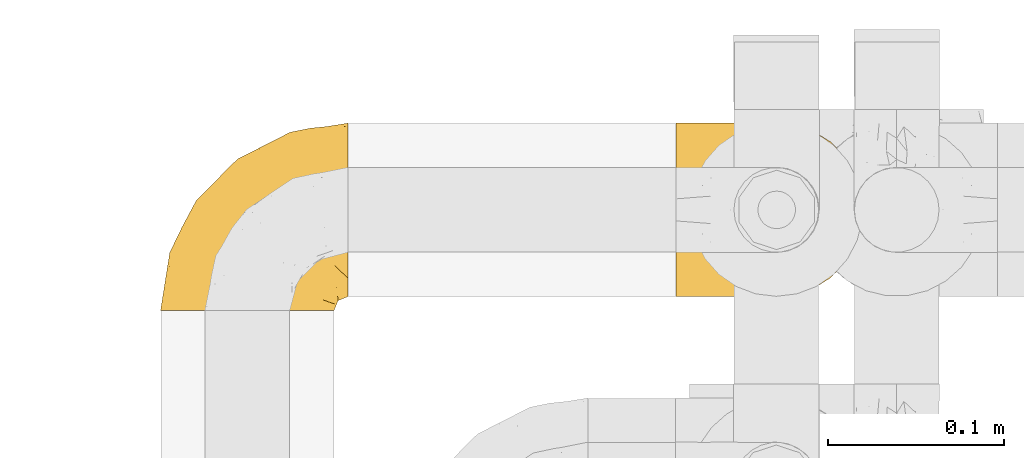
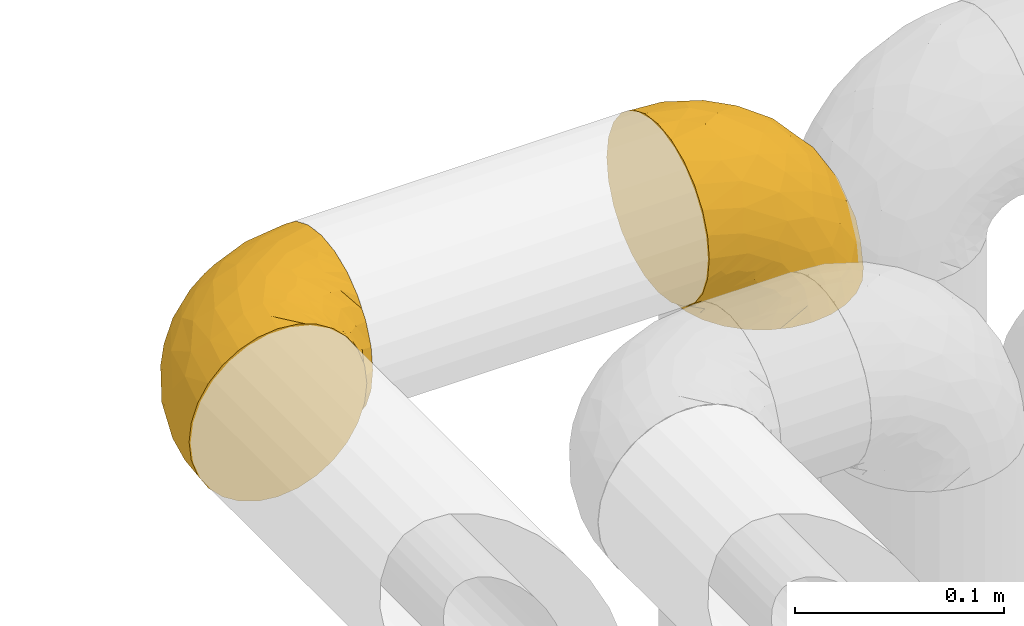
# One storey, part 401 of 827: 2 coverings.
"""IFC2X3 building model written with IfcOpenShell, lengths in millimetres."""

from ifc_helpers import new_model, entity, si_unit, converted_unit, derived_unit, direction, frame, origin, place, context, subcontext, project, spatial, faceted_brep, element, save


model = new_model("IFC2X3")

# Units and contexts
model_context = context("Model", 3, precision=0.01, world=origin(), true_north=direction((6.12303176911189e-17, 1.0)))
body_context = subcontext(model_context, "Body", "Model", "MODEL_VIEW")
ifc_project = project(units=[si_unit("LENGTHUNIT", "METRE", prefix="MILLI"), si_unit("AREAUNIT", "SQUARE_METRE"), si_unit("VOLUMEUNIT", "CUBIC_METRE"), converted_unit("PLANEANGLEUNIT", "DEGREE", entity("IfcRatioMeasure", 0.0174532925199433), si_unit("PLANEANGLEUNIT", "RADIAN"), dimensions=[0, 0, 0, 0, 0, 0, 0]), si_unit("MASSUNIT", "GRAM", prefix="KILO"), derived_unit("MASSDENSITYUNIT", [(si_unit("MASSUNIT", "GRAM", prefix="KILO"), 1), (si_unit("LENGTHUNIT", "METRE"), -3)]), derived_unit("MOMENTOFINERTIAUNIT", [(si_unit("LENGTHUNIT", "METRE"), 4)]), si_unit("TIMEUNIT", "SECOND"), si_unit("FREQUENCYUNIT", "HERTZ"), si_unit("THERMODYNAMICTEMPERATUREUNIT", "DEGREE_CELSIUS"), derived_unit("THERMALTRANSMITTANCEUNIT", [(si_unit("MASSUNIT", "GRAM", prefix="KILO"), 1), (si_unit("THERMODYNAMICTEMPERATUREUNIT", "KELVIN"), -1), (si_unit("TIMEUNIT", "SECOND"), -3)]), derived_unit("VOLUMETRICFLOWRATEUNIT", [(si_unit("LENGTHUNIT", "METRE"), 3), (si_unit("TIMEUNIT", "SECOND"), -1)]), derived_unit("MASSFLOWRATEUNIT", [(si_unit("MASSUNIT", "GRAM", prefix="KILO"), 1), (si_unit("TIMEUNIT", "SECOND"), -1)]), derived_unit("ROTATIONALFREQUENCYUNIT", [(si_unit("TIMEUNIT", "SECOND"), -1)]), si_unit("ELECTRICCURRENTUNIT", "AMPERE"), si_unit("ELECTRICVOLTAGEUNIT", "VOLT"), si_unit("POWERUNIT", "WATT"), si_unit("FORCEUNIT", "NEWTON", prefix="KILO"), si_unit("ILLUMINANCEUNIT", "LUX"), si_unit("LUMINOUSFLUXUNIT", "LUMEN"), si_unit("LUMINOUSINTENSITYUNIT", "CANDELA"), derived_unit("USERDEFINED", [(si_unit("MASSUNIT", "GRAM", prefix="KILO"), -1), (si_unit("LENGTHUNIT", "METRE"), -2), (si_unit("TIMEUNIT", "SECOND"), 3), (si_unit("LUMINOUSFLUXUNIT", "LUMEN"), 1)]), derived_unit("LINEARVELOCITYUNIT", [(si_unit("LENGTHUNIT", "METRE"), 1), (si_unit("TIMEUNIT", "SECOND"), -1)]), si_unit("PRESSUREUNIT", "PASCAL"), derived_unit("USERDEFINED", [(si_unit("LENGTHUNIT", "METRE"), -2), (si_unit("MASSUNIT", "GRAM", prefix="KILO"), 1), (si_unit("TIMEUNIT", "SECOND"), -2)]), derived_unit("LINEARFORCEUNIT", [(si_unit("MASSUNIT", "GRAM", prefix="KILO"), 1), (si_unit("LENGTHUNIT", "METRE"), 1), (si_unit("TIMEUNIT", "SECOND"), -2), (si_unit("LENGTHUNIT", "METRE"), -1)]), derived_unit("PLANARFORCEUNIT", [(si_unit("MASSUNIT", "GRAM", prefix="KILO"), 1), (si_unit("LENGTHUNIT", "METRE"), 1), (si_unit("TIMEUNIT", "SECOND"), -2), (si_unit("LENGTHUNIT", "METRE"), -2)])], contexts=[model_context])

# Site, building, storey
site_placement = place(None, origin())
site = spatial("IfcSite", under=ifc_project, at=site_placement, CompositionType="ELEMENT")
building_placement = place(site_placement, origin())
building = spatial("IfcBuilding", under=site, at=building_placement, CompositionType="ELEMENT")
storey_placement = place(building_placement, frame((0.0, 0.0, 28200.0)))
storey = spatial("IfcBuildingStorey", under=building, at=storey_placement, Name="08", CompositionType="ELEMENT", Elevation=28200.0)

# Coverings
covering_1_placement = place(storey_placement, frame((47301.25, 15248.43, 2949.25)))
element("IfcCovering", 1, at=covering_1_placement, inside=storey, Name=":ADSK_", ObjectType=":ADSK_", PredefinedType="INSULATION", context=body_context, shape_type="Brep", body=[
    faceted_brep([(50.75, 1.6, 99.9), (39.8, 1.6, 98.66), (29.41, 1.6, 95.02), (20.09, 1.6, 89.17), (12.31, 1.6, 81.38), (6.46, 1.6, 72.06), (2.83, 1.6, 61.68), (1.6, 1.6, 50.75), (2.83, 1.6, 39.8), (6.47, 1.6, 29.41), (12.32, 1.6, 20.09), (20.11, 1.6, 12.31), (29.43, 1.6, 6.46), (39.81, 1.6, 2.83), (50.75, 1.6, 1.6), (56.45, 1.6, 2.24), (61.69, 1.6, 2.83), (66.88, 1.6, 4.65), (72.08, 1.6, 6.47), (81.4, 1.6, 12.32), (89.18, 1.6, 20.11), (95.03, 1.6, 29.43), (98.66, 1.6, 39.81), (99.9, 1.6, 50.75), (98.66, 1.6, 61.69), (95.02, 1.6, 72.08), (89.17, 1.6, 81.4), (81.38, 1.6, 89.18), (72.06, 1.6, 95.03), (66.87, 1.6, 96.85), (61.68, 1.6, 98.66), (56.45, 1.6, 99.25), (53.6, 1.6, 99.57), (107.75, 11.12, 38.02), (107.75, 16.03, 26.17), (107.75, 19.94, 21.08), (107.75, 23.84, 15.99), (107.75, 28.93, 12.09), (107.75, 34.02, 8.18), (107.75, 39.95, 5.73), (107.75, 45.87, 3.27), (107.75, 52.86, 2.35), (107.75, 55.73, 1.97), (107.75, 58.6, 1.6), (107.75, 71.32, 3.27), (107.75, 83.17, 8.18), (107.75, 93.35, 15.99), (107.75, 101.16, 26.17), (107.75, 106.07, 38.02), (107.75, 107.75, 50.75), (107.75, 106.07, 63.47), (107.75, 101.16, 75.32), (107.75, 93.35, 85.5), (107.75, 83.17, 93.31), (107.75, 71.32, 98.22), (107.75, 58.6, 99.9), (107.75, 52.86, 99.14), (107.75, 45.87, 98.22), (107.75, 39.95, 95.77), (107.75, 34.02, 93.31), (107.75, 28.93, 89.4), (107.75, 23.84, 85.5), (107.75, 19.94, 80.41), (107.75, 16.03, 75.32), (107.75, 11.12, 63.47), (107.75, 9.45, 50.75), (39.38, 81.82, 59.31), (49.75, 84.02, 73.08), (57.38, 93.05, 63.72), (74.94, 102.55, 50.75), (85.97, 104.83, 58.64), (95.66, 105.83, 50.75), (67.82, 91.87, 76.74), (83.09, 101.74, 67.68), (89.16, 97.07, 78.92), (37.01, 38.45, 94.31), (43.46, 22.17, 98.76), (51.79, 42.04, 98.4), (85.58, 77.69, 94.57), (62.84, 75.76, 89.91), (62.77, 62.11, 96.32), (88.17, 66.08, 98.79), (85.93, 54.26, 99.9), (91.42, 55.35, 99.9), (96.91, 56.44, 99.9), (99.62, 56.98, 99.9), (102.33, 57.52, 99.9), (82.57, 87.84, 87.31), (32.75, 19.41, 95.61), (13.79, 48.89, 60.43), (6.77, 26.34, 65.24), (16.46, 44.55, 72.87), (55.08, 23.41, 99.9), (58.17, 28.03, 99.9), (61.26, 32.65, 99.9), (64.35, 37.28, 99.9), (67.44, 41.9, 99.9), (24.18, 20.6, 90.65), (23.37, 63.36, 63.14), (49.76, 62.21, 91.89), (9.84, 19.94, 75.25), (3.51, 13.68, 50.75), (55.75, 80.85, 82.18), (42.34, 66.53, 85.08), (37.78, 71.06, 76.93), (21.87, 63.99, 50.75), (33.61, 75.73, 50.75), (17.1, 26.77, 83.02), (51.28, 4.31, 99.9), (51.82, 7.01, 99.9), (52.9, 12.43, 99.9), (53.99, 17.92, 99.9), (28.01, 43.43, 87.13), (28.99, 56.23, 80.85), (69.9, 54.97, 99.17), (6.79, 34.4, 50.75), (72.06, 44.99, 99.9), (76.69, 48.08, 99.9), (81.31, 51.17, 99.9), (45.35, 87.47, 50.75), (34.79, 74.55, 67.61), (25.72, 60.86, 72.25), (14.33, 49.19, 50.75), (60.15, 95.01, 50.75), (62.38, 10.27, 98.69), (100.57, 48.79, 99.01), (91.06, 45.16, 98.79), (97.66, 44.99, 98.29), (97.55, 6.17, 68.51), (93.65, 7.65, 76.82), (66.85, 21.59, 98.54), (61.93, 19.96, 99.3), (101.4, 21.0, 83.57), (100.07, 27.2, 89.47), (101.36, 14.83, 75.76), (95.94, 19.7, 84.86), (96.3, 10.93, 75.89), (101.98, 9.63, 64.77), (85.88, 19.97, 90.83), (78.88, 21.13, 94.62), (82.8, 14.14, 90.37), (102.58, 30.2, 91.18), (82.88, 8.12, 88.65), (88.57, 9.93, 84.11), (88.67, 24.62, 91.75), (69.08, 11.87, 96.86), (102.19, 7.15, 50.75), (100.06, 5.32, 58.97), (70.56, 26.68, 98.37), (91.07, 13.92, 83.91), (77.56, 30.67, 97.52), (96.59, 36.65, 95.55), (86.38, 42.89, 98.76), (91.79, 34.04, 95.26), (81.71, 36.6, 98.04), (94.11, 26.41, 90.65), (76.09, 10.07, 93.51), (76.91, 15.83, 94.16), (81.44, 41.99, 99.1), (101.37, 14.83, 25.73), (94.12, 26.4, 10.84), (101.41, 21.01, 17.92), (95.96, 19.71, 16.64), (96.22, 5.72, 30.44), (66.85, 21.6, 2.95), (61.94, 19.96, 2.19), (58.17, 28.03, 1.6), (69.1, 11.87, 4.63), (88.58, 9.93, 17.39), (96.91, 56.44, 1.6), (102.33, 57.52, 1.6), (105.04, 58.06, 1.6), (82.9, 8.13, 12.86), (82.82, 14.15, 11.13), (97.66, 44.99, 3.2), (96.59, 36.65, 5.94), (100.07, 27.21, 12.02), (91.79, 34.04, 6.23), (102.58, 30.2, 10.31), (76.13, 10.06, 8.0), (76.93, 15.83, 7.34), (100.57, 48.79, 2.48), (86.38, 42.89, 2.73), (90.86, 45.38, 2.64), (52.9, 12.43, 1.6), (62.39, 10.28, 2.8), (101.98, 9.64, 36.71), (91.42, 55.35, 1.6), (85.93, 54.26, 1.6), (99.49, 6.05, 38.59), (51.82, 7.01, 1.6), (52.36, 9.72, 1.6), (61.26, 32.65, 1.6), (70.56, 26.68, 3.12), (91.09, 13.92, 17.59), (64.35, 37.28, 1.6), (77.6, 30.66, 3.98), (78.89, 21.14, 6.87), (81.71, 36.59, 3.45), (88.69, 24.6, 9.76), (53.99, 17.92, 1.6), (55.08, 23.41, 1.6), (96.31, 10.93, 25.62), (85.9, 19.97, 10.67), (81.45, 41.99, 2.39), (76.69, 48.08, 1.6), (81.31, 51.17, 1.6), (72.06, 44.99, 1.6), (67.44, 41.9, 1.6), (69.6, 55.26, 2.4), (85.97, 104.83, 42.85), (82.57, 87.84, 14.18), (63.16, 75.91, 11.56), (55.81, 80.84, 19.27), (67.81, 91.87, 24.75), (49.73, 83.98, 28.37), (32.55, 19.16, 5.95), (43.23, 22.37, 2.79), (88.17, 66.08, 2.71), (57.38, 93.05, 37.78), (83.08, 101.74, 33.81), (89.16, 97.07, 22.57), (85.58, 77.69, 6.92), (16.46, 44.55, 28.61), (6.77, 26.34, 36.24), (13.8, 48.9, 41.05), (37.71, 70.99, 24.55), (34.8, 74.55, 33.88), (36.83, 37.8, 7.11), (39.38, 81.82, 42.18), (17.12, 26.77, 18.46), (24.19, 20.6, 10.84), (28.89, 56.15, 20.69), (25.69, 60.85, 29.27), (51.77, 42.06, 3.1), (45.66, 57.03, 9.18), (23.39, 63.4, 38.38), (9.85, 19.94, 26.23), (28.11, 43.59, 14.34), (62.27, 62.61, 5.46), (42.35, 66.52, 16.39)], [[[0, 1, 2, 3, 4, 5, 6, 7, 8, 9, 10, 11, 12, 13, 14, 15, 16, 17, 18, 19, 20, 21, 22, 23, 24, 25, 26, 27, 28, 29, 30, 31, 32]], [[33, 34, 35, 36, 37, 38, 39, 40, 41, 42, 43, 44, 45, 46, 47, 48, 49, 50, 51, 52, 53, 54, 55, 56, 57, 58, 59, 60, 61, 62, 63, 64, 65]], [[66, 67, 68]], [[69, 70, 71]], [[68, 72, 73]], [[73, 72, 74]], [[75, 76, 77]], [[78, 79, 80]], [[51, 50, 73]], [[81, 82, 83, 84, 85, 86, 55]], [[52, 87, 53]], [[74, 52, 51]], [[2, 1, 88]], [[89, 90, 91]], [[77, 92, 93, 94, 95, 96]], [[55, 54, 81]], [[78, 53, 87]], [[5, 90, 6]], [[88, 76, 75]], [[97, 3, 2]], [[89, 91, 98]], [[99, 80, 79]], [[90, 5, 100]], [[74, 87, 52]], [[100, 5, 4]], [[90, 101, 6]], [[79, 102, 103]], [[102, 67, 104]], [[105, 98, 106]], [[107, 4, 3]], [[76, 0, 108, 109, 110, 111, 92]], [[107, 112, 113]], [[114, 77, 96]], [[89, 115, 90]], [[114, 96, 116, 117, 118, 82]], [[75, 97, 88]], [[119, 66, 68]], [[50, 71, 70]], [[100, 91, 90]], [[99, 77, 80]], [[102, 104, 103]], [[97, 107, 3]], [[80, 81, 78]], [[107, 97, 112]], [[68, 73, 70]], [[66, 98, 120]], [[78, 81, 54]], [[114, 81, 80]], [[53, 78, 54]], [[78, 87, 79]], [[102, 87, 72]], [[79, 103, 99]], [[4, 107, 100]], [[91, 100, 107]], [[88, 97, 2]], [[112, 97, 75]], [[99, 112, 75]], [[103, 104, 113]], [[91, 121, 98]], [[89, 105, 122, 115]], [[101, 90, 115]], [[101, 7, 6]], [[88, 1, 76]], [[0, 76, 1]], [[92, 77, 76]], [[73, 74, 51]], [[87, 74, 72]], [[81, 114, 82]], [[77, 114, 80]], [[87, 102, 79]], [[67, 102, 72]], [[68, 67, 72]], [[67, 120, 104]], [[120, 121, 104]], [[104, 121, 113]], [[121, 120, 98]], [[91, 107, 113]], [[91, 113, 121]], [[103, 113, 112]], [[106, 98, 66]], [[105, 89, 98]], [[106, 66, 119]], [[67, 66, 120]], [[68, 69, 123, 119]], [[50, 49, 71]], [[50, 70, 73]], [[112, 99, 103]], [[77, 99, 75]], [[69, 68, 70]], [[29, 124, 110]], [[84, 83, 125]], [[126, 82, 118]], [[59, 58, 127]], [[25, 128, 129]], [[130, 93, 131]], [[132, 62, 133]], [[134, 135, 136]], [[137, 65, 64]], [[64, 134, 137]], [[138, 139, 140]], [[111, 110, 124, 92]], [[134, 136, 137]], [[134, 64, 63]], [[141, 61, 60]], [[125, 58, 57]], [[142, 143, 140]], [[142, 26, 143]], [[127, 83, 82]], [[28, 124, 29]], [[108, 0, 32, 31, 30, 110, 109]], [[30, 29, 110]], [[135, 144, 138]], [[28, 145, 124]], [[57, 56, 55, 86, 85, 84]], [[146, 147, 23]], [[24, 23, 147]], [[25, 143, 26]], [[95, 94, 148]], [[24, 128, 25]], [[149, 138, 143]], [[124, 145, 131]], [[127, 58, 125]], [[150, 148, 139]], [[127, 126, 151]], [[151, 59, 127]], [[152, 151, 126]], [[153, 154, 155]], [[153, 133, 141]], [[145, 28, 27]], [[142, 156, 27]], [[157, 148, 130]], [[61, 133, 62]], [[134, 132, 135]], [[147, 128, 24]], [[65, 137, 146]], [[146, 137, 147]], [[128, 137, 136]], [[137, 128, 147]], [[128, 136, 129]], [[149, 129, 136]], [[25, 129, 143]], [[158, 152, 117]], [[152, 118, 117]], [[153, 151, 152]], [[158, 116, 154]], [[144, 150, 138]], [[153, 152, 158]], [[133, 153, 155]], [[133, 155, 132]], [[60, 151, 141]], [[135, 132, 155]], [[134, 63, 132]], [[144, 135, 155]], [[135, 138, 149]], [[155, 154, 144]], [[150, 154, 96]], [[154, 150, 144]], [[148, 94, 130]], [[82, 126, 127]], [[118, 152, 126]], [[150, 96, 95]], [[139, 148, 157]], [[150, 95, 148]], [[93, 92, 131]], [[130, 145, 156]], [[130, 94, 93]], [[84, 125, 57]], [[127, 125, 83]], [[140, 139, 157]], [[150, 139, 138]], [[140, 157, 142]], [[138, 140, 143]], [[156, 142, 157]], [[27, 26, 142]], [[130, 156, 157]], [[145, 27, 156]], [[132, 63, 62]], [[124, 131, 92]], [[130, 131, 145]], [[129, 149, 143]], [[135, 149, 136]], [[141, 133, 61]], [[60, 59, 151]], [[141, 151, 153]], [[116, 96, 154]], [[153, 158, 154]], [[158, 117, 116]], [[34, 33, 159]], [[160, 161, 162]], [[22, 21, 163]], [[164, 165, 166]], [[19, 18, 167]], [[168, 21, 20]], [[42, 41, 40, 169, 170, 171, 43]], [[172, 173, 168]], [[174, 38, 175]], [[176, 177, 178]], [[179, 164, 180]], [[40, 181, 169]], [[182, 183, 175]], [[17, 184, 185]], [[65, 146, 186]], [[187, 174, 188]], [[23, 22, 189]], [[174, 39, 38]], [[15, 14, 190, 191, 184, 16]], [[181, 40, 39]], [[192, 193, 164]], [[194, 163, 168]], [[33, 186, 159]], [[180, 173, 172]], [[195, 196, 193]], [[18, 185, 167]], [[173, 180, 197]], [[198, 199, 196]], [[200, 201, 185, 184]], [[184, 17, 16]], [[18, 17, 185]], [[202, 159, 186]], [[194, 168, 203]], [[189, 163, 202]], [[204, 205, 182]], [[187, 181, 174]], [[160, 177, 176]], [[206, 183, 182]], [[206, 182, 205]], [[201, 165, 185]], [[165, 164, 167]], [[172, 179, 180]], [[202, 194, 162]], [[176, 161, 160]], [[65, 186, 33]], [[163, 189, 22]], [[175, 177, 182]], [[174, 183, 188]], [[177, 198, 204]], [[199, 160, 162]], [[198, 207, 204]], [[175, 38, 37]], [[198, 177, 160]], [[178, 177, 175]], [[176, 35, 161]], [[34, 159, 161]], [[162, 161, 159]], [[202, 162, 159]], [[199, 162, 203]], [[196, 199, 203]], [[198, 160, 199]], [[193, 197, 180]], [[208, 198, 196]], [[188, 183, 206]], [[175, 183, 174]], [[193, 192, 195]], [[195, 208, 196]], [[197, 196, 203]], [[180, 164, 193]], [[168, 163, 21]], [[166, 165, 201]], [[166, 192, 164]], [[189, 202, 186]], [[186, 146, 189]], [[23, 189, 146]], [[174, 181, 39]], [[169, 181, 187]], [[196, 197, 193]], [[173, 203, 168]], [[203, 173, 197]], [[172, 168, 20]], [[20, 19, 172]], [[179, 172, 19]], [[19, 167, 179]], [[164, 179, 167]], [[35, 176, 36]], [[35, 34, 161]], [[185, 165, 167]], [[162, 194, 203]], [[163, 194, 202]], [[176, 178, 36]], [[37, 36, 178]], [[175, 37, 178]], [[177, 204, 182]], [[207, 198, 208]], [[207, 205, 204]], [[209, 188, 206, 205, 207, 208]], [[48, 210, 71]], [[211, 212, 213]], [[214, 213, 215]], [[216, 217, 13]], [[218, 43, 171, 170, 169, 187, 188]], [[219, 220, 214]], [[47, 46, 221]], [[210, 48, 220]], [[211, 222, 212]], [[222, 45, 44]], [[221, 220, 47]], [[47, 220, 48]], [[221, 211, 214]], [[223, 224, 225]], [[211, 46, 45]], [[226, 227, 215]], [[43, 218, 44]], [[217, 216, 228]], [[219, 215, 229]], [[14, 13, 217]], [[224, 9, 8]], [[10, 230, 11]], [[11, 231, 12]], [[232, 223, 233]], [[234, 208, 195, 192, 166, 201]], [[235, 234, 228]], [[222, 44, 218]], [[106, 229, 236]], [[224, 237, 9]], [[231, 238, 228]], [[9, 237, 10]], [[115, 224, 101]], [[239, 234, 235]], [[231, 11, 230]], [[223, 230, 237]], [[224, 8, 101]], [[223, 236, 233]], [[225, 115, 122, 105]], [[216, 12, 231]], [[209, 234, 239]], [[210, 219, 69]], [[219, 214, 215]], [[229, 119, 219]], [[209, 218, 188]], [[239, 212, 222]], [[239, 222, 218]], [[45, 222, 211]], [[235, 212, 239]], [[213, 212, 240]], [[223, 237, 224]], [[230, 10, 237]], [[238, 231, 230]], [[216, 231, 228]], [[232, 230, 223]], [[235, 238, 240]], [[115, 225, 224]], [[233, 236, 227]], [[8, 7, 101]], [[234, 209, 208]], [[218, 209, 239]], [[217, 228, 234]], [[13, 12, 216]], [[234, 201, 217]], [[217, 201, 200, 184, 191, 190, 14]], [[211, 221, 46]], [[220, 221, 214]], [[71, 210, 69]], [[71, 49, 48]], [[219, 210, 220]], [[226, 215, 213]], [[211, 213, 214]], [[226, 213, 240]], [[215, 227, 229]], [[232, 240, 238]], [[233, 227, 226]], [[232, 233, 226]], [[236, 223, 225]], [[240, 232, 226]], [[232, 238, 230]], [[225, 105, 236]], [[236, 105, 106]], [[236, 229, 227]], [[123, 69, 219, 119]], [[106, 119, 229]], [[238, 235, 228]], [[212, 235, 240]]]),
])
covering_2_placement = place(storey_placement, frame((47593.4, 15256.28, 2941.4)))
element("IfcCovering", 2, at=covering_2_placement, inside=storey, Name=":ADSK_", ObjectType=":ADSK_", PredefinedType="INSULATION", context=body_context, shape_type="Brep", body=[
    faceted_brep([(58.6, 99.9, 1.6), (69.54, 98.66, 1.6), (79.93, 95.02, 1.6), (89.25, 89.17, 1.6), (97.03, 81.38, 1.6), (102.88, 72.06, 1.6), (106.51, 61.68, 1.6), (107.75, 50.75, 1.6), (106.51, 39.8, 1.6), (102.87, 29.41, 1.6), (97.02, 20.09, 1.6), (89.23, 12.31, 1.6), (79.91, 6.46, 1.6), (69.53, 2.83, 1.6), (58.6, 1.6, 1.6), (52.89, 2.24, 1.6), (47.65, 2.83, 1.6), (42.46, 4.65, 1.6), (37.26, 6.47, 1.6), (27.94, 12.32, 1.6), (20.16, 20.11, 1.6), (14.31, 29.43, 1.6), (10.68, 39.81, 1.6), (9.45, 50.75, 1.6), (10.68, 61.69, 1.6), (14.32, 72.08, 1.6), (20.17, 81.4, 1.6), (27.96, 89.18, 1.6), (37.28, 95.03, 1.6), (42.47, 96.85, 1.6), (47.66, 98.66, 1.6), (52.89, 99.25, 1.6), (55.75, 99.57, 1.6), (1.6, 38.02, 11.12), (1.6, 26.17, 16.03), (1.6, 21.08, 19.94), (1.6, 15.99, 23.84), (1.6, 12.09, 28.93), (1.6, 8.18, 34.02), (1.6, 5.73, 39.95), (1.6, 3.27, 45.87), (1.6, 2.35, 52.86), (1.6, 1.97, 55.73), (1.6, 1.6, 58.6), (1.6, 3.27, 71.32), (1.6, 8.18, 83.17), (1.6, 15.99, 93.35), (1.6, 26.17, 101.16), (1.6, 38.02, 106.07), (1.6, 50.75, 107.75), (1.6, 63.47, 106.07), (1.6, 75.32, 101.16), (1.6, 85.5, 93.35), (1.6, 93.31, 83.17), (1.6, 98.22, 71.32), (1.6, 99.9, 58.6), (1.6, 99.14, 52.86), (1.6, 98.22, 45.87), (1.6, 95.77, 39.95), (1.6, 93.31, 34.02), (1.6, 89.4, 28.93), (1.6, 85.5, 23.84), (1.6, 80.41, 19.94), (1.6, 75.32, 16.03), (1.6, 63.47, 11.12), (1.6, 50.75, 9.45), (69.96, 59.31, 81.82), (59.59, 73.08, 84.02), (51.96, 63.72, 93.05), (34.4, 50.75, 102.55), (23.37, 58.64, 104.83), (13.68, 50.75, 105.83), (41.52, 76.74, 91.87), (26.26, 67.68, 101.74), (20.18, 78.92, 97.07), (72.33, 94.31, 38.45), (65.88, 98.76, 22.17), (57.55, 98.4, 42.04), (23.76, 94.57, 77.69), (46.5, 89.91, 75.76), (46.57, 96.32, 62.11), (21.17, 98.79, 66.08), (23.41, 99.9, 54.26), (17.92, 99.9, 55.35), (12.43, 99.9, 56.44), (9.72, 99.9, 56.98), (7.01, 99.9, 57.52), (26.77, 87.31, 87.84), (76.59, 95.61, 19.41), (95.55, 60.43, 48.89), (102.57, 65.24, 26.34), (92.89, 72.87, 44.55), (54.26, 99.9, 23.41), (51.17, 99.9, 28.03), (48.08, 99.9, 32.65), (44.99, 99.9, 37.28), (41.9, 99.9, 41.9), (85.16, 90.65, 20.6), (85.97, 63.14, 63.36), (59.58, 91.89, 62.21), (99.5, 75.25, 19.94), (105.83, 50.75, 13.68), (53.59, 82.18, 80.85), (67.0, 85.08, 66.53), (71.56, 76.93, 71.06), (87.47, 50.75, 63.99), (75.73, 50.75, 75.73), (92.24, 83.02, 26.77), (58.06, 99.9, 4.31), (57.52, 99.9, 7.01), (56.44, 99.9, 12.43), (55.35, 99.9, 17.92), (81.33, 87.13, 43.43), (80.35, 80.85, 56.23), (39.44, 99.17, 54.97), (102.55, 50.75, 34.4), (37.28, 99.9, 44.99), (32.65, 99.9, 48.08), (28.03, 99.9, 51.17), (63.99, 50.75, 87.47), (74.55, 67.61, 74.55), (83.62, 72.25, 60.86), (95.01, 50.75, 49.19), (49.19, 50.75, 95.01), (46.96, 98.69, 10.27), (8.77, 99.01, 48.79), (18.28, 98.79, 45.16), (11.68, 98.29, 44.99), (11.79, 68.51, 6.17), (15.69, 76.82, 7.65), (42.49, 98.54, 21.59), (47.41, 99.3, 19.96), (7.94, 83.57, 21.0), (9.27, 89.47, 27.2), (7.98, 75.76, 14.83), (13.4, 84.86, 19.7), (13.04, 75.89, 10.93), (7.36, 64.77, 9.63), (23.46, 90.83, 19.97), (30.46, 94.62, 21.13), (26.54, 90.37, 14.14), (6.76, 91.18, 30.2), (26.46, 88.65, 8.12), (20.77, 84.11, 9.93), (20.68, 91.75, 24.62), (40.26, 96.86, 11.87), (7.15, 50.75, 7.15), (9.28, 58.97, 5.32), (38.78, 98.37, 26.68), (18.27, 83.91, 13.92), (31.78, 97.52, 30.67), (12.75, 95.55, 36.65), (22.96, 98.76, 42.89), (17.55, 95.26, 34.04), (27.63, 98.04, 36.6), (15.23, 90.65, 26.41), (33.25, 93.51, 10.07), (32.43, 94.16, 15.83), (27.9, 99.1, 41.99), (7.97, 25.73, 14.83), (15.22, 10.84, 26.4), (7.93, 17.92, 21.01), (13.38, 16.64, 19.71), (13.12, 30.44, 5.72), (42.49, 2.95, 21.6), (47.4, 2.19, 19.96), (51.17, 1.6, 28.03), (40.24, 4.63, 11.87), (20.76, 17.39, 9.93), (12.43, 1.6, 56.44), (7.01, 1.6, 57.52), (4.31, 1.6, 58.06), (26.44, 12.86, 8.13), (26.52, 11.13, 14.15), (11.68, 3.2, 44.99), (12.75, 5.94, 36.65), (9.27, 12.02, 27.21), (17.55, 6.23, 34.04), (6.76, 10.31, 30.2), (33.21, 8.0, 10.06), (32.41, 7.34, 15.83), (8.77, 2.48, 48.79), (22.96, 2.73, 42.89), (18.48, 2.64, 45.38), (56.44, 1.6, 12.43), (46.95, 2.8, 10.28), (7.36, 36.71, 9.64), (17.92, 1.6, 55.35), (23.41, 1.6, 54.26), (9.85, 38.59, 6.05), (57.52, 1.6, 7.01), (56.98, 1.6, 9.72), (48.08, 1.6, 32.65), (38.78, 3.12, 26.68), (18.25, 17.59, 13.92), (44.99, 1.6, 37.28), (31.74, 3.98, 30.66), (30.45, 6.87, 21.14), (27.63, 3.45, 36.59), (20.65, 9.76, 24.6), (55.35, 1.6, 17.92), (54.26, 1.6, 23.41), (13.03, 25.62, 10.93), (23.44, 10.67, 19.97), (27.9, 2.39, 41.99), (32.65, 1.6, 48.08), (28.03, 1.6, 51.17), (37.28, 1.6, 44.99), (41.9, 1.6, 41.9), (39.74, 2.4, 55.26), (23.37, 42.85, 104.83), (26.77, 14.18, 87.84), (46.18, 11.56, 75.91), (53.54, 19.27, 80.84), (41.53, 24.75, 91.87), (59.61, 28.37, 83.98), (76.79, 5.95, 19.16), (66.11, 2.79, 22.37), (21.17, 2.71, 66.08), (51.96, 37.78, 93.05), (26.26, 33.81, 101.74), (20.18, 22.57, 97.07), (23.76, 6.92, 77.69), (92.88, 28.61, 44.55), (102.57, 36.24, 26.34), (95.54, 41.05, 48.9), (71.63, 24.55, 70.99), (74.55, 33.88, 74.55), (72.51, 7.11, 37.8), (69.96, 42.18, 81.82), (92.23, 18.46, 26.77), (85.15, 10.84, 20.6), (80.45, 20.69, 56.15), (83.65, 29.27, 60.85), (57.57, 3.1, 42.06), (63.68, 9.18, 57.03), (85.95, 38.38, 63.4), (99.49, 26.23, 19.94), (81.23, 14.34, 43.59), (47.07, 5.46, 62.61), (66.99, 16.39, 66.52)], [[[0, 1, 2, 3, 4, 5, 6, 7, 8, 9, 10, 11, 12, 13, 14, 15, 16, 17, 18, 19, 20, 21, 22, 23, 24, 25, 26, 27, 28, 29, 30, 31, 32]], [[33, 34, 35, 36, 37, 38, 39, 40, 41, 42, 43, 44, 45, 46, 47, 48, 49, 50, 51, 52, 53, 54, 55, 56, 57, 58, 59, 60, 61, 62, 63, 64, 65]], [[66, 67, 68]], [[69, 70, 71]], [[68, 72, 73]], [[73, 72, 74]], [[75, 76, 77]], [[78, 79, 80]], [[51, 50, 73]], [[81, 82, 83, 84, 85, 86, 55]], [[52, 87, 53]], [[74, 52, 51]], [[2, 1, 88]], [[89, 90, 91]], [[77, 92, 93, 94, 95, 96]], [[55, 54, 81]], [[78, 53, 87]], [[5, 90, 6]], [[88, 76, 75]], [[97, 3, 2]], [[89, 91, 98]], [[99, 80, 79]], [[90, 5, 100]], [[74, 87, 52]], [[100, 5, 4]], [[90, 101, 6]], [[79, 102, 103]], [[102, 67, 104]], [[105, 98, 106]], [[107, 4, 3]], [[76, 0, 108, 109, 110, 111, 92]], [[107, 112, 113]], [[114, 77, 96]], [[89, 115, 90]], [[114, 96, 116, 117, 118, 82]], [[75, 97, 88]], [[119, 66, 68]], [[50, 71, 70]], [[100, 91, 90]], [[99, 77, 80]], [[102, 104, 103]], [[97, 107, 3]], [[80, 81, 78]], [[107, 97, 112]], [[68, 73, 70]], [[66, 98, 120]], [[78, 81, 54]], [[114, 81, 80]], [[53, 78, 54]], [[78, 87, 79]], [[102, 87, 72]], [[79, 103, 99]], [[4, 107, 100]], [[91, 100, 107]], [[88, 97, 2]], [[112, 97, 75]], [[99, 112, 75]], [[103, 104, 113]], [[91, 121, 98]], [[89, 105, 122, 115]], [[101, 90, 115]], [[101, 7, 6]], [[88, 1, 76]], [[0, 76, 1]], [[92, 77, 76]], [[73, 74, 51]], [[87, 74, 72]], [[81, 114, 82]], [[77, 114, 80]], [[87, 102, 79]], [[67, 102, 72]], [[68, 67, 72]], [[67, 120, 104]], [[120, 121, 104]], [[104, 121, 113]], [[121, 120, 98]], [[91, 107, 113]], [[91, 113, 121]], [[103, 113, 112]], [[106, 98, 66]], [[105, 89, 98]], [[106, 66, 119]], [[67, 66, 120]], [[68, 69, 123, 119]], [[50, 49, 71]], [[50, 70, 73]], [[112, 99, 103]], [[77, 99, 75]], [[69, 68, 70]], [[29, 124, 110]], [[84, 83, 125]], [[126, 82, 118]], [[59, 58, 127]], [[25, 128, 129]], [[130, 93, 131]], [[132, 62, 133]], [[134, 135, 136]], [[137, 65, 64]], [[64, 134, 137]], [[138, 139, 140]], [[111, 110, 124, 92]], [[134, 136, 137]], [[134, 64, 63]], [[141, 61, 60]], [[125, 58, 57]], [[142, 143, 140]], [[142, 26, 143]], [[127, 83, 82]], [[28, 124, 29]], [[108, 0, 32, 31, 30, 110, 109]], [[30, 29, 110]], [[135, 144, 138]], [[28, 145, 124]], [[57, 56, 55, 86, 85, 84]], [[146, 147, 23]], [[24, 23, 147]], [[25, 143, 26]], [[95, 94, 148]], [[24, 128, 25]], [[149, 138, 143]], [[124, 145, 131]], [[127, 58, 125]], [[150, 148, 139]], [[127, 126, 151]], [[151, 59, 127]], [[152, 151, 126]], [[153, 154, 155]], [[153, 133, 141]], [[145, 28, 27]], [[142, 156, 27]], [[157, 148, 130]], [[61, 133, 62]], [[134, 132, 135]], [[147, 128, 24]], [[65, 137, 146]], [[146, 137, 147]], [[128, 137, 136]], [[137, 128, 147]], [[128, 136, 129]], [[149, 129, 136]], [[25, 129, 143]], [[158, 152, 117]], [[152, 118, 117]], [[153, 151, 152]], [[158, 116, 154]], [[144, 150, 138]], [[153, 152, 158]], [[133, 153, 155]], [[133, 155, 132]], [[60, 151, 141]], [[135, 132, 155]], [[134, 63, 132]], [[144, 135, 155]], [[135, 138, 149]], [[155, 154, 144]], [[150, 154, 96]], [[154, 150, 144]], [[148, 94, 130]], [[82, 126, 127]], [[118, 152, 126]], [[150, 96, 95]], [[139, 148, 157]], [[150, 95, 148]], [[93, 92, 131]], [[130, 145, 156]], [[130, 94, 93]], [[84, 125, 57]], [[127, 125, 83]], [[140, 139, 157]], [[150, 139, 138]], [[140, 157, 142]], [[138, 140, 143]], [[156, 142, 157]], [[27, 26, 142]], [[130, 156, 157]], [[145, 27, 156]], [[132, 63, 62]], [[124, 131, 92]], [[130, 131, 145]], [[129, 149, 143]], [[135, 149, 136]], [[141, 133, 61]], [[60, 59, 151]], [[141, 151, 153]], [[116, 96, 154]], [[153, 158, 154]], [[158, 117, 116]], [[34, 33, 159]], [[160, 161, 162]], [[22, 21, 163]], [[164, 165, 166]], [[19, 18, 167]], [[168, 21, 20]], [[42, 41, 40, 169, 170, 171, 43]], [[172, 173, 168]], [[174, 38, 175]], [[176, 177, 178]], [[179, 164, 180]], [[40, 181, 169]], [[182, 183, 175]], [[17, 184, 185]], [[65, 146, 186]], [[187, 174, 188]], [[23, 22, 189]], [[174, 39, 38]], [[15, 14, 190, 191, 184, 16]], [[181, 40, 39]], [[192, 193, 164]], [[194, 163, 168]], [[33, 186, 159]], [[180, 173, 172]], [[195, 196, 193]], [[18, 185, 167]], [[173, 180, 197]], [[198, 199, 196]], [[200, 201, 185, 184]], [[184, 17, 16]], [[18, 17, 185]], [[202, 159, 186]], [[194, 168, 203]], [[189, 163, 202]], [[204, 205, 182]], [[187, 181, 174]], [[160, 177, 176]], [[206, 183, 182]], [[206, 182, 205]], [[201, 165, 185]], [[165, 164, 167]], [[172, 179, 180]], [[202, 194, 162]], [[176, 161, 160]], [[65, 186, 33]], [[163, 189, 22]], [[175, 177, 182]], [[174, 183, 188]], [[177, 198, 204]], [[199, 160, 162]], [[198, 207, 204]], [[175, 38, 37]], [[198, 177, 160]], [[178, 177, 175]], [[176, 35, 161]], [[34, 159, 161]], [[162, 161, 159]], [[202, 162, 159]], [[199, 162, 203]], [[196, 199, 203]], [[198, 160, 199]], [[193, 197, 180]], [[208, 198, 196]], [[188, 183, 206]], [[175, 183, 174]], [[193, 192, 195]], [[195, 208, 196]], [[197, 196, 203]], [[180, 164, 193]], [[168, 163, 21]], [[166, 165, 201]], [[166, 192, 164]], [[189, 202, 186]], [[186, 146, 189]], [[23, 189, 146]], [[174, 181, 39]], [[169, 181, 187]], [[196, 197, 193]], [[173, 203, 168]], [[203, 173, 197]], [[172, 168, 20]], [[20, 19, 172]], [[179, 172, 19]], [[19, 167, 179]], [[164, 179, 167]], [[35, 176, 36]], [[35, 34, 161]], [[185, 165, 167]], [[162, 194, 203]], [[163, 194, 202]], [[176, 178, 36]], [[37, 36, 178]], [[175, 37, 178]], [[177, 204, 182]], [[207, 198, 208]], [[207, 205, 204]], [[209, 188, 206, 205, 207, 208]], [[48, 210, 71]], [[211, 212, 213]], [[214, 213, 215]], [[216, 217, 13]], [[218, 43, 171, 170, 169, 187, 188]], [[219, 220, 214]], [[47, 46, 221]], [[210, 48, 220]], [[211, 222, 212]], [[222, 45, 44]], [[221, 220, 47]], [[47, 220, 48]], [[221, 211, 214]], [[223, 224, 225]], [[211, 46, 45]], [[226, 227, 215]], [[43, 218, 44]], [[217, 216, 228]], [[219, 215, 229]], [[14, 13, 217]], [[224, 9, 8]], [[10, 230, 11]], [[11, 231, 12]], [[232, 223, 233]], [[234, 208, 195, 192, 166, 201]], [[235, 234, 228]], [[222, 44, 218]], [[106, 229, 236]], [[224, 237, 9]], [[231, 238, 228]], [[9, 237, 10]], [[115, 224, 101]], [[239, 234, 235]], [[231, 11, 230]], [[223, 230, 237]], [[224, 8, 101]], [[223, 236, 233]], [[225, 115, 122, 105]], [[216, 12, 231]], [[209, 234, 239]], [[210, 219, 69]], [[219, 214, 215]], [[229, 119, 219]], [[209, 218, 188]], [[239, 212, 222]], [[239, 222, 218]], [[45, 222, 211]], [[235, 212, 239]], [[213, 212, 240]], [[223, 237, 224]], [[230, 10, 237]], [[238, 231, 230]], [[216, 231, 228]], [[232, 230, 223]], [[235, 238, 240]], [[115, 225, 224]], [[233, 236, 227]], [[8, 7, 101]], [[234, 209, 208]], [[218, 209, 239]], [[217, 228, 234]], [[13, 12, 216]], [[234, 201, 217]], [[217, 201, 200, 184, 191, 190, 14]], [[211, 221, 46]], [[220, 221, 214]], [[71, 210, 69]], [[71, 49, 48]], [[219, 210, 220]], [[226, 215, 213]], [[211, 213, 214]], [[226, 213, 240]], [[215, 227, 229]], [[232, 240, 238]], [[233, 227, 226]], [[232, 233, 226]], [[236, 223, 225]], [[240, 232, 226]], [[232, 238, 230]], [[225, 105, 236]], [[236, 105, 106]], [[236, 229, 227]], [[123, 69, 219, 119]], [[106, 119, 229]], [[238, 235, 228]], [[212, 235, 240]]]),
])

save(model, "model.ifc")
